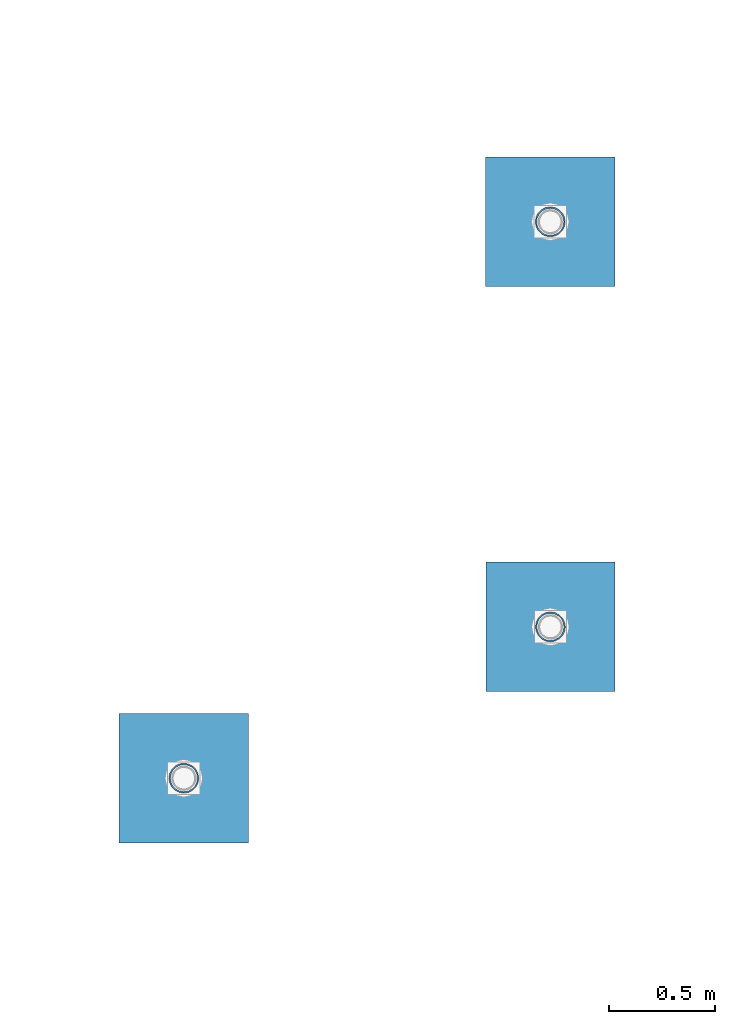
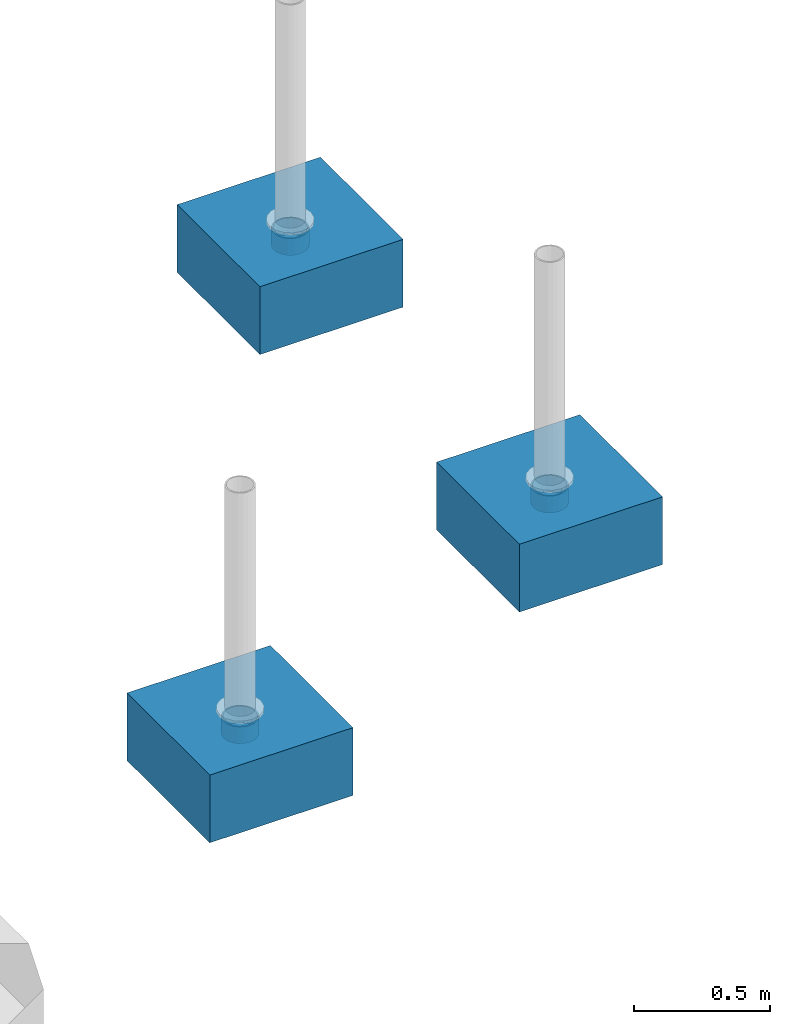
# One storey, part 1437 of 3843: 6 columns, 6 elements without a shape of their own.
"""IFC2X3 building model written with IfcOpenShell, lengths in millimetres."""

from ifc_helpers import new_model, si_unit, frame, origin_with_axes, place, context, subcontext, project, spatial, faceted_brep, material, type_object, element, aggregate, save


model = new_model("IFC2X3")

# Units and contexts
model_context = context("Model", 3, precision=1e-05, world=origin_with_axes())
body_context = subcontext(model_context, "Body", "Model", "MODEL_VIEW")
ifc_project = project(units=[si_unit("LENGTHUNIT", "METRE", prefix="MILLI"), si_unit("AREAUNIT", "SQUARE_METRE"), si_unit("VOLUMEUNIT", "CUBIC_METRE"), si_unit("MASSUNIT", "GRAM", prefix="KILO"), si_unit("TIMEUNIT", "SECOND"), si_unit("PLANEANGLEUNIT", "RADIAN"), si_unit("SOLIDANGLEUNIT", "STERADIAN"), si_unit("THERMODYNAMICTEMPERATUREUNIT", "DEGREE_CELSIUS"), si_unit("LUMINOUSINTENSITYUNIT", "LUMEN")], contexts=[model_context])

# Site, building, storey
site_placement = place(None, origin_with_axes())
site = spatial("IfcSite", under=ifc_project, at=site_placement, CompositionType="ELEMENT")
building_placement = place(site_placement, origin_with_axes())
building = spatial("IfcBuilding", under=site, at=building_placement, Name="Undefined", CompositionType="ELEMENT")
storey_placement = place(building_placement, origin_with_axes())
storey = spatial("IfcBuildingStorey", under=building, at=storey_placement, Name="Undefined", CompositionType="ELEMENT", Elevation=0.0)

# Assembly, column
assembly_1_placement = place(storey_placement, origin_with_axes())
assembly_1 = element("IfcElementAssembly", 1, at=assembly_1_placement, inside=storey, Name="PLATE", AssemblyPlace="NOTDEFINED", PredefinedType="RIGID_FRAME")
ifc_material_1 = material()
column_type_1 = type_object("IfcColumnType", Name="PIPE5SCH40", PredefinedType="NOTDEFINED")
column_1_placement = place(assembly_1_placement, frame((3266.14378336072, 39556.0458376408, 30378.4), z_axis=(-1.0, 0.0, 0.0), x_axis=(0.0, 0.0, 1.0)))
column_1 = element("IfcColumn", 2, at=column_1_placement, type_object=column_type_1, material=ifc_material_1, Name="PIPE_SLEEVE", ObjectType="PIPE5SCH40", context=body_context, shape_type="Brep", body=[
    faceted_brep([(0.0, -64.0587999999998, 0.0), (0.0, -60.9235391660477, 19.7952578392724), (76.2000000000007, -60.9235391660477, 19.7952578392724), (76.2000000000007, -64.0587999999998, 0.0), (0.0, -51.8246578392655, 37.6528179195593), (76.2000000000007, -51.8246578392655, 37.6528179195593), (0.0, -37.6528179195529, 51.8246578392718), (76.2000000000007, -37.6528179195529, 51.8246578392718), (0.0, -19.795257839266, 60.9235391660477), (76.2000000000007, -19.795257839266, 60.9235391660477), (0.0, 0.0, 64.0587999999989), (76.2000000000007, 0.0, 64.0587999999989), (0.0, 19.795257839266, 60.9235391660477), (76.2000000000007, 19.795257839266, 60.9235391660477), (0.0, 37.6528179195529, 51.8246578392718), (76.2000000000007, 37.6528179195529, 51.8246578392718), (0.0, 51.8246578392655, 37.6528179195593), (76.2000000000007, 51.8246578392655, 37.6528179195593), (0.0, 60.9235391660477, 19.7952578392724), (76.2000000000007, 60.9235391660477, 19.7952578392724), (0.0, 64.0587999999998, 0.0), (76.2000000000007, 64.0587999999998, 0.0), (0.0, 60.9235391660477, -19.7952578392724), (76.2000000000007, 60.9235391660477, -19.7952578392724), (0.0, 51.8246578392655, -37.6528179195593), (76.2000000000007, 51.8246578392655, -37.6528179195593), (0.0, 37.6528179195529, -51.8246578392718), (76.2000000000007, 37.6528179195529, -51.8246578392718), (0.0, 19.795257839266, -60.9235391660477), (76.2000000000007, 19.795257839266, -60.9235391660477), (0.0, 0.0, -64.0587999999989), (76.2000000000007, 0.0, -64.0587999999989), (0.0, -19.795257839266, -60.9235391660477), (76.2000000000007, -19.795257839266, -60.9235391660477), (0.0, -37.6528179195529, -51.8246578392718), (76.2000000000007, -37.6528179195529, -51.8246578392718), (0.0, -51.8246578392655, -37.6528179195593), (76.2000000000007, -51.8246578392655, -37.6528179195593), (0.0, -60.9235391660477, -19.7952578392724), (76.2000000000007, -60.9235391660477, -19.7952578392724), (0.0, -70.6120000000001, 0.0), (0.0, -67.1560027286332, -21.8203080068051), (76.2000000000007, -67.1560027286332, -21.8203080068051), (76.2000000000007, -70.6120000000001, 0.0), (0.0, -57.1263080068038, -41.5046922348702), (76.2000000000007, -57.1263080068038, -41.5046922348702), (0.0, -41.5046922348765, -57.126308006802), (76.2000000000007, -41.5046922348765, -57.126308006802), (0.0, -21.8203080068042, -67.1560027286323), (76.2000000000007, -21.8203080068042, -67.1560027286323), (0.0, 0.0, -70.6119999999937), (76.2000000000007, 0.0, -70.6119999999937), (0.0, 21.8203080068042, -67.1560027286323), (76.2000000000007, 21.8203080068042, -67.1560027286323), (0.0, 41.5046922348765, -57.126308006802), (76.2000000000007, 41.5046922348765, -57.126308006802), (0.0, 57.1263080068038, -41.5046922348702), (76.2000000000007, 57.1263080068038, -41.5046922348702), (0.0, 67.1560027286332, -21.8203080068051), (76.2000000000007, 67.1560027286332, -21.8203080068051), (0.0, 70.6120000000001, 0.0), (76.2000000000007, 70.6120000000001, 0.0), (0.0, 67.1560027286332, 21.8203080068051), (76.2000000000007, 67.1560027286332, 21.8203080068051), (0.0, 57.1263080068038, 41.5046922348702), (76.2000000000007, 57.1263080068038, 41.5046922348702), (0.0, 41.5046922348765, 57.126308006802), (76.2000000000007, 41.5046922348765, 57.126308006802), (0.0, 21.8203080068042, 67.1560027286323), (76.2000000000007, 21.8203080068042, 67.1560027286323), (0.0, 0.0, 70.6119999999937), (76.2000000000007, 0.0, 70.6119999999937), (0.0, -21.8203080068042, 67.1560027286323), (76.2000000000007, -21.8203080068042, 67.1560027286323), (0.0, -41.5046922348765, 57.126308006802), (76.2000000000007, -41.5046922348765, 57.126308006802), (0.0, -57.1263080068038, 41.5046922348702), (76.2000000000007, -57.1263080068038, 41.5046922348702), (0.0, -67.1560027286332, 21.8203080068051), (76.2000000000007, -67.1560027286332, 21.8203080068051)], [[[0, 1, 2, 3]], [[1, 4, 5, 2]], [[4, 6, 7, 5]], [[6, 8, 9, 7]], [[8, 10, 11, 9]], [[10, 12, 13, 11]], [[12, 14, 15, 13]], [[14, 16, 17, 15]], [[16, 18, 19, 17]], [[18, 20, 21, 19]], [[20, 22, 23, 21]], [[22, 24, 25, 23]], [[24, 26, 27, 25]], [[26, 28, 29, 27]], [[28, 30, 31, 29]], [[30, 32, 33, 31]], [[32, 34, 35, 33]], [[34, 36, 37, 35]], [[36, 38, 39, 37]], [[38, 0, 3, 39]], [[40, 41, 42, 43]], [[41, 44, 45, 42]], [[44, 46, 47, 45]], [[46, 48, 49, 47]], [[48, 50, 51, 49]], [[50, 52, 53, 51]], [[52, 54, 55, 53]], [[54, 56, 57, 55]], [[56, 58, 59, 57]], [[58, 60, 61, 59]], [[60, 62, 63, 61]], [[62, 64, 65, 63]], [[64, 66, 67, 65]], [[66, 68, 69, 67]], [[68, 70, 71, 69]], [[70, 72, 73, 71]], [[72, 74, 75, 73]], [[74, 76, 77, 75]], [[76, 78, 79, 77]], [[78, 40, 43, 79]], [[45, 47, 49, 51, 53, 55, 57, 59, 61, 63, 65, 67, 69, 71, 73, 75, 77, 79, 43, 42], [5, 7, 9, 11, 13, 15, 17, 19, 21, 23, 25, 27, 29, 31, 33, 35, 37, 39, 3, 2]], [[78, 76, 74, 72, 70, 68, 66, 64, 62, 60, 58, 56, 54, 52, 50, 48, 46, 44, 41, 40], [38, 36, 34, 32, 30, 28, 26, 24, 22, 20, 18, 16, 14, 12, 10, 8, 6, 4, 1, 0]]]),
])
aggregate(assembly_1, [column_1])

assembly_2_placement = place(storey_placement, origin_with_axes())
assembly_2 = element("IfcElementAssembly", 3, at=assembly_2_placement, inside=storey, Name="PLATE", AssemblyPlace="NOTDEFINED", PredefinedType="RIGID_FRAME")
column_2_placement = place(assembly_2_placement, frame((3266.91244485974, 37645.7255556583, 30378.4), z_axis=(-1.0, 0.0, 0.0), x_axis=(0.0, 0.0, 1.0)))
column_2 = element("IfcColumn", 4, at=column_2_placement, type_object=column_type_1, material=ifc_material_1, Name="PIPE_SLEEVE", ObjectType="PIPE5SCH40", context=body_context, shape_type="Brep", body=[
    faceted_brep([(0.0, -64.0587999999998, 0.0), (0.0, -60.9235391660477, 19.7952578392724), (76.2000000000007, -60.9235391660477, 19.7952578392724), (76.2000000000007, -64.0587999999998, 0.0), (0.0, -51.8246578392655, 37.6528179195593), (76.2000000000007, -51.8246578392655, 37.6528179195593), (0.0, -37.6528179195529, 51.8246578392718), (76.2000000000007, -37.6528179195529, 51.8246578392718), (0.0, -19.795257839266, 60.9235391660477), (76.2000000000007, -19.795257839266, 60.9235391660477), (0.0, 0.0, 64.0587999999989), (76.2000000000007, 0.0, 64.0587999999989), (0.0, 19.795257839266, 60.9235391660477), (76.2000000000007, 19.795257839266, 60.9235391660477), (0.0, 37.6528179195529, 51.8246578392718), (76.2000000000007, 37.6528179195529, 51.8246578392718), (0.0, 51.8246578392655, 37.6528179195593), (76.2000000000007, 51.8246578392655, 37.6528179195593), (0.0, 60.9235391660477, 19.7952578392724), (76.2000000000007, 60.9235391660477, 19.7952578392724), (0.0, 64.0587999999998, 0.0), (76.2000000000007, 64.0587999999998, 0.0), (0.0, 60.9235391660477, -19.7952578392724), (76.2000000000007, 60.9235391660477, -19.7952578392724), (0.0, 51.8246578392655, -37.6528179195593), (76.2000000000007, 51.8246578392655, -37.6528179195593), (0.0, 37.6528179195529, -51.8246578392718), (76.2000000000007, 37.6528179195529, -51.8246578392718), (0.0, 19.795257839266, -60.9235391660477), (76.2000000000007, 19.795257839266, -60.9235391660477), (0.0, 0.0, -64.0587999999989), (76.2000000000007, 0.0, -64.0587999999989), (0.0, -19.795257839266, -60.9235391660477), (76.2000000000007, -19.795257839266, -60.9235391660477), (0.0, -37.6528179195529, -51.8246578392718), (76.2000000000007, -37.6528179195529, -51.8246578392718), (0.0, -51.8246578392655, -37.6528179195593), (76.2000000000007, -51.8246578392655, -37.6528179195593), (0.0, -60.9235391660477, -19.7952578392724), (76.2000000000007, -60.9235391660477, -19.7952578392724), (0.0, -70.6120000000001, 0.0), (0.0, -67.1560027286332, -21.8203080068051), (76.2000000000007, -67.1560027286332, -21.8203080068051), (76.2000000000007, -70.6120000000001, 0.0), (0.0, -57.1263080068038, -41.5046922348702), (76.2000000000007, -57.1263080068038, -41.5046922348702), (0.0, -41.5046922348765, -57.126308006802), (76.2000000000007, -41.5046922348765, -57.126308006802), (0.0, -21.8203080068042, -67.1560027286323), (76.2000000000007, -21.8203080068042, -67.1560027286323), (0.0, 0.0, -70.6119999999937), (76.2000000000007, 0.0, -70.6119999999937), (0.0, 21.8203080068042, -67.1560027286323), (76.2000000000007, 21.8203080068042, -67.1560027286323), (0.0, 41.5046922348765, -57.126308006802), (76.2000000000007, 41.5046922348765, -57.126308006802), (0.0, 57.1263080068038, -41.5046922348702), (76.2000000000007, 57.1263080068038, -41.5046922348702), (0.0, 67.1560027286332, -21.8203080068051), (76.2000000000007, 67.1560027286332, -21.8203080068051), (0.0, 70.6120000000001, 0.0), (76.2000000000007, 70.6120000000001, 0.0), (0.0, 67.1560027286332, 21.8203080068051), (76.2000000000007, 67.1560027286332, 21.8203080068051), (0.0, 57.1263080068038, 41.5046922348702), (76.2000000000007, 57.1263080068038, 41.5046922348702), (0.0, 41.5046922348765, 57.126308006802), (76.2000000000007, 41.5046922348765, 57.126308006802), (0.0, 21.8203080068042, 67.1560027286323), (76.2000000000007, 21.8203080068042, 67.1560027286323), (0.0, 0.0, 70.6119999999937), (76.2000000000007, 0.0, 70.6119999999937), (0.0, -21.8203080068042, 67.1560027286323), (76.2000000000007, -21.8203080068042, 67.1560027286323), (0.0, -41.5046922348765, 57.126308006802), (76.2000000000007, -41.5046922348765, 57.126308006802), (0.0, -57.1263080068038, 41.5046922348702), (76.2000000000007, -57.1263080068038, 41.5046922348702), (0.0, -67.1560027286332, 21.8203080068051), (76.2000000000007, -67.1560027286332, 21.8203080068051)], [[[0, 1, 2, 3]], [[1, 4, 5, 2]], [[4, 6, 7, 5]], [[6, 8, 9, 7]], [[8, 10, 11, 9]], [[10, 12, 13, 11]], [[12, 14, 15, 13]], [[14, 16, 17, 15]], [[16, 18, 19, 17]], [[18, 20, 21, 19]], [[20, 22, 23, 21]], [[22, 24, 25, 23]], [[24, 26, 27, 25]], [[26, 28, 29, 27]], [[28, 30, 31, 29]], [[30, 32, 33, 31]], [[32, 34, 35, 33]], [[34, 36, 37, 35]], [[36, 38, 39, 37]], [[38, 0, 3, 39]], [[40, 41, 42, 43]], [[41, 44, 45, 42]], [[44, 46, 47, 45]], [[46, 48, 49, 47]], [[48, 50, 51, 49]], [[50, 52, 53, 51]], [[52, 54, 55, 53]], [[54, 56, 57, 55]], [[56, 58, 59, 57]], [[58, 60, 61, 59]], [[60, 62, 63, 61]], [[62, 64, 65, 63]], [[64, 66, 67, 65]], [[66, 68, 69, 67]], [[68, 70, 71, 69]], [[70, 72, 73, 71]], [[72, 74, 75, 73]], [[74, 76, 77, 75]], [[76, 78, 79, 77]], [[78, 40, 43, 79]], [[45, 47, 49, 51, 53, 55, 57, 59, 61, 63, 65, 67, 69, 71, 73, 75, 77, 79, 43, 42], [5, 7, 9, 11, 13, 15, 17, 19, 21, 23, 25, 27, 29, 31, 33, 35, 37, 39, 3, 2]], [[78, 76, 74, 72, 70, 68, 66, 64, 62, 60, 58, 56, 54, 52, 50, 48, 46, 44, 41, 40], [38, 36, 34, 32, 30, 28, 26, 24, 22, 20, 18, 16, 14, 12, 10, 8, 6, 4, 1, 0]]]),
])
aggregate(assembly_2, [column_2])

assembly_3_placement = place(storey_placement, origin_with_axes())
assembly_3 = element("IfcElementAssembly", 5, at=assembly_3_placement, inside=storey, Name="PLATE", AssemblyPlace="NOTDEFINED", PredefinedType="RIGID_FRAME")
column_3_placement = place(assembly_3_placement, frame((1538.06970956921, 36931.9728090763, 30378.4), z_axis=(-1.0, 0.0, 0.0), x_axis=(0.0, 0.0, 1.0)))
column_3 = element("IfcColumn", 6, at=column_3_placement, type_object=column_type_1, material=ifc_material_1, Name="PIPE_SLEEVE", ObjectType="PIPE5SCH40", context=body_context, shape_type="Brep", body=[
    faceted_brep([(0.0, -64.0587999999998, 0.0), (0.0, -60.9235391660477, 19.7952578392724), (76.2000000000007, -60.9235391660477, 19.7952578392724), (76.2000000000007, -64.0587999999998, 0.0), (0.0, -51.8246578392655, 37.6528179195593), (76.2000000000007, -51.8246578392655, 37.6528179195593), (0.0, -37.6528179195529, 51.8246578392718), (76.2000000000007, -37.6528179195529, 51.8246578392718), (0.0, -19.795257839266, 60.9235391660477), (76.2000000000007, -19.795257839266, 60.9235391660477), (0.0, 0.0, 64.0587999999989), (76.2000000000007, 0.0, 64.0587999999989), (0.0, 19.795257839266, 60.9235391660477), (76.2000000000007, 19.795257839266, 60.9235391660477), (0.0, 37.6528179195529, 51.8246578392718), (76.2000000000007, 37.6528179195529, 51.8246578392718), (0.0, 51.8246578392655, 37.6528179195593), (76.2000000000007, 51.8246578392655, 37.6528179195593), (0.0, 60.9235391660477, 19.7952578392724), (76.2000000000007, 60.9235391660477, 19.7952578392724), (0.0, 64.0587999999998, 0.0), (76.2000000000007, 64.0587999999998, 0.0), (0.0, 60.9235391660477, -19.7952578392724), (76.2000000000007, 60.9235391660477, -19.7952578392724), (0.0, 51.8246578392655, -37.6528179195593), (76.2000000000007, 51.8246578392655, -37.6528179195593), (0.0, 37.6528179195529, -51.8246578392718), (76.2000000000007, 37.6528179195529, -51.8246578392718), (0.0, 19.795257839266, -60.9235391660477), (76.2000000000007, 19.795257839266, -60.9235391660477), (0.0, 0.0, -64.0587999999989), (76.2000000000007, 0.0, -64.0587999999989), (0.0, -19.795257839266, -60.9235391660477), (76.2000000000007, -19.795257839266, -60.9235391660477), (0.0, -37.6528179195529, -51.8246578392718), (76.2000000000007, -37.6528179195529, -51.8246578392718), (0.0, -51.8246578392655, -37.6528179195593), (76.2000000000007, -51.8246578392655, -37.6528179195593), (0.0, -60.9235391660477, -19.7952578392724), (76.2000000000007, -60.9235391660477, -19.7952578392724), (0.0, -70.6120000000001, 0.0), (0.0, -67.1560027286332, -21.8203080068051), (76.2000000000007, -67.1560027286332, -21.8203080068051), (76.2000000000007, -70.6120000000001, 0.0), (0.0, -57.1263080068038, -41.5046922348702), (76.2000000000007, -57.1263080068038, -41.5046922348702), (0.0, -41.5046922348765, -57.126308006802), (76.2000000000007, -41.5046922348765, -57.126308006802), (0.0, -21.8203080068042, -67.1560027286323), (76.2000000000007, -21.8203080068042, -67.1560027286323), (0.0, 0.0, -70.6119999999937), (76.2000000000007, 0.0, -70.6119999999937), (0.0, 21.8203080068042, -67.1560027286323), (76.2000000000007, 21.8203080068042, -67.1560027286323), (0.0, 41.5046922348765, -57.126308006802), (76.2000000000007, 41.5046922348765, -57.126308006802), (0.0, 57.1263080068038, -41.5046922348702), (76.2000000000007, 57.1263080068038, -41.5046922348702), (0.0, 67.1560027286332, -21.8203080068051), (76.2000000000007, 67.1560027286332, -21.8203080068051), (0.0, 70.6120000000001, 0.0), (76.2000000000007, 70.6120000000001, 0.0), (0.0, 67.1560027286332, 21.8203080068051), (76.2000000000007, 67.1560027286332, 21.8203080068051), (0.0, 57.1263080068038, 41.5046922348702), (76.2000000000007, 57.1263080068038, 41.5046922348702), (0.0, 41.5046922348765, 57.126308006802), (76.2000000000007, 41.5046922348765, 57.126308006802), (0.0, 21.8203080068042, 67.1560027286323), (76.2000000000007, 21.8203080068042, 67.1560027286323), (0.0, 0.0, 70.6119999999937), (76.2000000000007, 0.0, 70.6119999999937), (0.0, -21.8203080068042, 67.1560027286323), (76.2000000000007, -21.8203080068042, 67.1560027286323), (0.0, -41.5046922348765, 57.126308006802), (76.2000000000007, -41.5046922348765, 57.126308006802), (0.0, -57.1263080068038, 41.5046922348702), (76.2000000000007, -57.1263080068038, 41.5046922348702), (0.0, -67.1560027286332, 21.8203080068051), (76.2000000000007, -67.1560027286332, 21.8203080068051)], [[[0, 1, 2, 3]], [[1, 4, 5, 2]], [[4, 6, 7, 5]], [[6, 8, 9, 7]], [[8, 10, 11, 9]], [[10, 12, 13, 11]], [[12, 14, 15, 13]], [[14, 16, 17, 15]], [[16, 18, 19, 17]], [[18, 20, 21, 19]], [[20, 22, 23, 21]], [[22, 24, 25, 23]], [[24, 26, 27, 25]], [[26, 28, 29, 27]], [[28, 30, 31, 29]], [[30, 32, 33, 31]], [[32, 34, 35, 33]], [[34, 36, 37, 35]], [[36, 38, 39, 37]], [[38, 0, 3, 39]], [[40, 41, 42, 43]], [[41, 44, 45, 42]], [[44, 46, 47, 45]], [[46, 48, 49, 47]], [[48, 50, 51, 49]], [[50, 52, 53, 51]], [[52, 54, 55, 53]], [[54, 56, 57, 55]], [[56, 58, 59, 57]], [[58, 60, 61, 59]], [[60, 62, 63, 61]], [[62, 64, 65, 63]], [[64, 66, 67, 65]], [[66, 68, 69, 67]], [[68, 70, 71, 69]], [[70, 72, 73, 71]], [[72, 74, 75, 73]], [[74, 76, 77, 75]], [[76, 78, 79, 77]], [[78, 40, 43, 79]], [[45, 47, 49, 51, 53, 55, 57, 59, 61, 63, 65, 67, 69, 71, 73, 75, 77, 79, 43, 42], [5, 7, 9, 11, 13, 15, 17, 19, 21, 23, 25, 27, 29, 31, 33, 35, 37, 39, 3, 2]], [[78, 76, 74, 72, 70, 68, 66, 64, 62, 60, 58, 56, 54, 52, 50, 48, 46, 44, 41, 40], [38, 36, 34, 32, 30, 28, 26, 24, 22, 20, 18, 16, 14, 12, 10, 8, 6, 4, 1, 0]]]),
])
aggregate(assembly_3, [column_3])

assembly_4_placement = place(storey_placement, origin_with_axes())
assembly_4 = element("IfcElementAssembly", 7, at=assembly_4_placement, inside=storey, Name="CONC_COL.", AssemblyPlace="NOTDEFINED", PredefinedType="REINFORCEMENT_UNIT")
ifc_material_2 = material(Name="CONCRETE/3000")
column_type_2 = type_object("IfcColumnType", PredefinedType="NOTDEFINED")
column_4_placement = place(assembly_4_placement, frame((3266.14378336072, 39556.0458376408, 30175.2), z_axis=(-1.0, 0.0, 0.0), x_axis=(0.0, 0.0, 1.0)))
column_4 = element("IfcColumn", 8, at=column_4_placement, type_object=column_type_2, material=ifc_material_2, Name="CONC_COL.", context=body_context, shape_type="Brep", body=[
    faceted_brep([(0.0, 304.8, -304.800000000003), (0.0, 304.8, 304.800000000003), (304.799999999999, 304.8, 304.800000000003), (304.799999999999, 304.8, -304.800000000003), (0.0, -304.8, 304.800000000003), (304.799999999999, -304.8, 304.800000000003), (0.0, -304.8, -304.800000000003), (304.799999999999, -304.8, -304.800000000003)], [[[0, 1, 2, 3]], [[1, 4, 5, 2]], [[4, 6, 7, 5]], [[6, 0, 3, 7]], [[5, 7, 3, 2]], [[6, 4, 1, 0]]]),
])
aggregate(assembly_4, [column_4])

assembly_5_placement = place(storey_placement, origin_with_axes())
assembly_5 = element("IfcElementAssembly", 9, at=assembly_5_placement, inside=storey, Name="CONC_COL.", AssemblyPlace="NOTDEFINED", PredefinedType="REINFORCEMENT_UNIT")
column_5_placement = place(assembly_5_placement, frame((3266.91244485974, 37645.7255556583, 30175.2), z_axis=(-1.0, 0.0, 0.0), x_axis=(0.0, 0.0, 1.0)))
column_5 = element("IfcColumn", 10, at=column_5_placement, type_object=column_type_2, material=ifc_material_2, Name="CONC_COL.", context=body_context, shape_type="Brep", body=[
    faceted_brep([(0.0, 304.8, -304.800000000003), (0.0, 304.8, 304.800000000003), (304.799999999999, 304.8, 304.800000000003), (304.799999999999, 304.8, -304.800000000003), (0.0, -304.8, 304.800000000003), (304.799999999999, -304.8, 304.800000000003), (0.0, -304.8, -304.800000000003), (304.799999999999, -304.8, -304.800000000003)], [[[0, 1, 2, 3]], [[1, 4, 5, 2]], [[4, 6, 7, 5]], [[6, 0, 3, 7]], [[5, 7, 3, 2]], [[6, 4, 1, 0]]]),
])
aggregate(assembly_5, [column_5])

assembly_6_placement = place(storey_placement, origin_with_axes())
assembly_6 = element("IfcElementAssembly", 11, at=assembly_6_placement, inside=storey, Name="CONC_COL.", AssemblyPlace="NOTDEFINED", PredefinedType="REINFORCEMENT_UNIT")
column_6_placement = place(assembly_6_placement, frame((1538.06970956921, 36931.9728090763, 30175.2), z_axis=(-1.0, 0.0, 0.0), x_axis=(0.0, 0.0, 1.0)))
column_6 = element("IfcColumn", 12, at=column_6_placement, type_object=column_type_2, material=ifc_material_2, Name="CONC_COL.", context=body_context, shape_type="Brep", body=[
    faceted_brep([(0.0, 304.8, -304.800000000003), (0.0, 304.8, 304.800000000003), (304.799999999999, 304.8, 304.800000000003), (304.799999999999, 304.8, -304.800000000003), (0.0, -304.8, 304.800000000003), (304.799999999999, -304.8, 304.800000000003), (0.0, -304.8, -304.800000000003), (304.799999999999, -304.8, -304.800000000003)], [[[0, 1, 2, 3]], [[1, 4, 5, 2]], [[4, 6, 7, 5]], [[6, 0, 3, 7]], [[5, 7, 3, 2]], [[6, 4, 1, 0]]]),
])
aggregate(assembly_6, [column_6])

save(model, "model.ifc")
